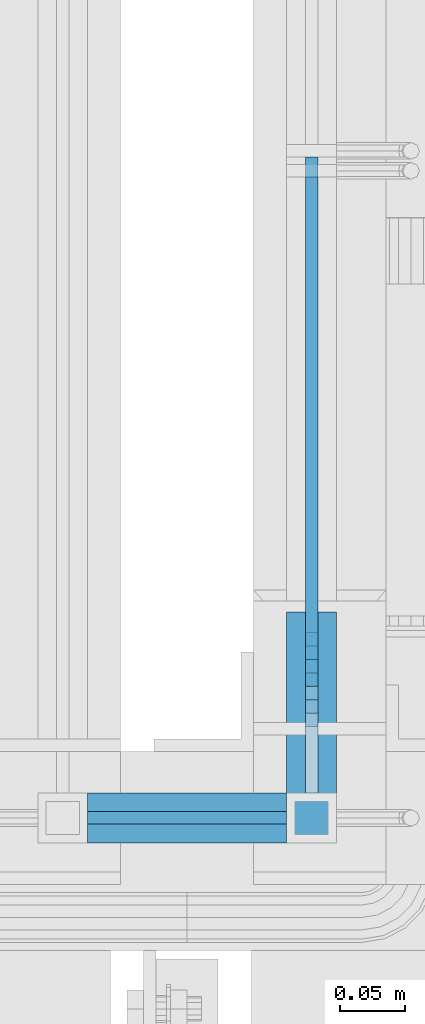
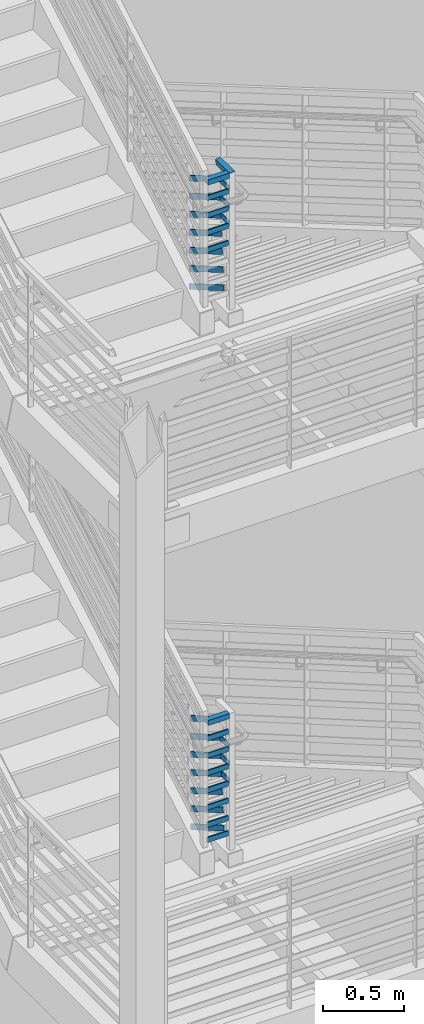
# One storey, part 859 of 1179: 19 beams, 15 members, 2 elements without a shape of their own.
"""IFC2X3 building model written with IfcOpenShell, lengths in millimetres."""

from ifc_helpers import new_model, si_unit, frame, origin_with_axes, place, context, subcontext, project, spatial, faceted_brep, material, type_object, element, aggregate, save


model = new_model("IFC2X3")

# Units and contexts
model_context = context("Model", 3, precision=1e-05, world=origin_with_axes())
body_context = subcontext(model_context, "Body", "Model", "MODEL_VIEW")
ifc_project = project(units=[si_unit("LENGTHUNIT", "METRE", prefix="MILLI"), si_unit("AREAUNIT", "SQUARE_METRE"), si_unit("VOLUMEUNIT", "CUBIC_METRE"), si_unit("MASSUNIT", "GRAM", prefix="KILO"), si_unit("TIMEUNIT", "SECOND"), si_unit("PLANEANGLEUNIT", "RADIAN"), si_unit("SOLIDANGLEUNIT", "STERADIAN"), si_unit("THERMODYNAMICTEMPERATUREUNIT", "DEGREE_CELSIUS"), si_unit("LUMINOUSINTENSITYUNIT", "LUMEN")], contexts=[model_context])

# Site, building, storey
site_placement = place(None, origin_with_axes())
site = spatial("IfcSite", under=ifc_project, at=site_placement, CompositionType="ELEMENT")
building_placement = place(site_placement, origin_with_axes())
building = spatial("IfcBuilding", under=site, at=building_placement, Name="Undefined", CompositionType="ELEMENT")
storey_placement = place(building_placement, origin_with_axes())
storey = spatial("IfcBuildingStorey", under=building, at=storey_placement, Name="Undefined", CompositionType="ELEMENT", Elevation=0.0)

# Assembly, beams
assembly_1_placement = place(storey_placement, origin_with_axes())
assembly_1 = element("IfcElementAssembly", 1, at=assembly_1_placement, inside=storey, Name="GUARDRAIL", AssemblyPlace="NOTDEFINED", PredefinedType="RIGID_FRAME")
ifc_material_1 = material(Name="STEEL/A36")
beam_type_1 = type_object("IfcBeamType", PredefinedType="NOTDEFINED")
beam_1_placement = place(assembly_1_placement, frame((-1828.80000153055, 31737.299999989, 6740.52488299739), z_axis=(0.0, 0.0, 1.0), x_axis=(0.999999999938439, 1.10960000217655e-05, 0.0)))
beam_1 = element("IfcBeam", 2, at=beam_1_placement, type_object=beam_type_1, material=ifc_material_1, Name="PLATE", context=body_context, shape_type="Brep", body=[
    faceted_brep([(0.0, 4.76250000000073, -19.05), (0.0, 4.76250000000073, 19.0499992370605), (152.399956117868, 4.76250000043365, 19.0500000000002), (152.399956117868, 4.76250000043365, -19.0500000000002), (0.0, -4.76250000000073, 19.0499992370605), (152.399956117868, -4.76249999959691, 19.0500000000002), (0.0, -4.76250000000073, -19.05), (152.399956117868, -4.76249999959691, -19.0500000000002)], [[[0, 1, 2, 3]], [[1, 4, 5, 2]], [[4, 6, 7, 5]], [[6, 0, 3, 7]], [[5, 7, 3, 2]], [[6, 4, 1, 0]]]),
])
beam_2_placement = place(assembly_1_placement, frame((-1828.80000153055, 31737.299999989, 6870.69988299459), z_axis=(0.0, 0.0, 1.0), x_axis=(0.999999999938439, 1.10960000217655e-05, 0.0)))
beam_2 = element("IfcBeam", 3, at=beam_2_placement, type_object=beam_type_1, material=ifc_material_1, Name="PLATE", context=body_context, shape_type="Brep", body=[
    faceted_brep([(0.0, 4.76250000000073, -19.05), (0.0, 4.76250000000073, 19.0499992370605), (152.399956117868, 4.76250000043365, 19.0500000000002), (152.399956117868, 4.76250000043365, -19.0500000000002), (0.0, -4.76250000000073, 19.0499992370605), (152.399956117868, -4.76249999959691, 19.0500000000002), (0.0, -4.76250000000073, -19.05), (152.399956117868, -4.76249999959691, -19.0500000000002)], [[[0, 1, 2, 3]], [[1, 4, 5, 2]], [[4, 6, 7, 5]], [[6, 0, 3, 7]], [[5, 7, 3, 2]], [[6, 4, 1, 0]]]),
])
beam_3_placement = place(assembly_1_placement, frame((-1828.80000153055, 31737.299999989, 7000.87488299804), z_axis=(0.0, 0.0, 1.0), x_axis=(0.999999999938439, 1.10960000217655e-05, 0.0)))
beam_3 = element("IfcBeam", 4, at=beam_3_placement, type_object=beam_type_1, material=ifc_material_1, Name="PLATE", context=body_context, shape_type="Brep", body=[
    faceted_brep([(0.0, 4.76250000000073, -19.05), (0.0, 4.76250000000073, 19.0499992370605), (152.399956117868, 4.76250000043365, 19.0500000000002), (152.399956117868, 4.76250000043365, -19.0500000000002), (0.0, -4.76250000000073, 19.0499992370605), (152.399956117868, -4.76249999959691, 19.0500000000002), (0.0, -4.76250000000073, -19.05), (152.399956117868, -4.76249999959691, -19.0500000000002)], [[[0, 1, 2, 3]], [[1, 4, 5, 2]], [[4, 6, 7, 5]], [[6, 0, 3, 7]], [[5, 7, 3, 2]], [[6, 4, 1, 0]]]),
])
beam_4_placement = place(assembly_1_placement, frame((-1828.80000153055, 31737.299999989, 7131.04988300441), z_axis=(0.0, 0.0, 1.0), x_axis=(0.999999999938439, 1.10960000217655e-05, 0.0)))
beam_4 = element("IfcBeam", 5, at=beam_4_placement, type_object=beam_type_1, material=ifc_material_1, Name="PLATE", context=body_context, shape_type="Brep", body=[
    faceted_brep([(0.0, 4.76250000000073, -19.05), (0.0, 4.76250000000073, 19.0499992370605), (152.399956117868, 4.76250000043365, 19.0500000000002), (152.399956117868, 4.76250000043365, -19.0500000000002), (0.0, -4.76250000000073, 19.0499992370605), (152.399956117868, -4.76249999959691, 19.0500000000002), (0.0, -4.76250000000073, -19.05), (152.399956117868, -4.76249999959691, -19.0500000000002)], [[[0, 1, 2, 3]], [[1, 4, 5, 2]], [[4, 6, 7, 5]], [[6, 0, 3, 7]], [[5, 7, 3, 2]], [[6, 4, 1, 0]]]),
])

assembly_2_placement = place(storey_placement, origin_with_axes())
assembly_2 = element("IfcElementAssembly", 6, at=assembly_2_placement, inside=storey, Name="GUARDRAIL", AssemblyPlace="NOTDEFINED", PredefinedType="RIGID_FRAME")
beam_5_placement = place(assembly_2_placement, frame((-1828.80000153055, 31737.299999338, 2292.40288892326), z_axis=(0.0, 0.0, 1.0), x_axis=(0.999999999938439, 1.10960000217655e-05, 0.0)))
beam_5 = element("IfcBeam", 7, at=beam_5_placement, type_object=beam_type_1, material=ifc_material_1, Name="PLATE", context=body_context, shape_type="Brep", body=[
    faceted_brep([(0.0, 4.76250000000073, -19.05), (0.0, 4.76250000000073, 19.0499992370605), (152.399956117868, 4.76250000043365, 19.0500000000002), (152.399956117868, 4.76250000043365, -19.0500000000002), (0.0, -4.76250000000073, 19.0499992370605), (152.399956117868, -4.76249999959691, 19.0500000000002), (0.0, -4.76250000000073, -19.05), (152.399956117868, -4.76249999959691, -19.0500000000002)], [[[0, 1, 2, 3]], [[1, 4, 5, 2]], [[4, 6, 7, 5]], [[6, 0, 3, 7]], [[5, 7, 3, 2]], [[6, 4, 1, 0]]]),
])
beam_6_placement = place(assembly_2_placement, frame((-1828.80000153055, 31737.299999338, 2406.70288909744), z_axis=(0.0, 0.0, 1.0), x_axis=(0.999999999938439, 1.10960000217655e-05, 0.0)))
beam_6 = element("IfcBeam", 8, at=beam_6_placement, type_object=beam_type_1, material=ifc_material_1, Name="PLATE", context=body_context, shape_type="Brep", body=[
    faceted_brep([(0.0, 4.76250000000073, -19.05), (0.0, 4.76250000000073, 19.0499992370605), (152.399956117868, 4.76250000043365, 19.0500000000002), (152.399956117868, 4.76250000043365, -19.0500000000002), (0.0, -4.76250000000073, 19.0499992370605), (152.399956117868, -4.76249999959691, 19.0500000000002), (0.0, -4.76250000000073, -19.05), (152.399956117868, -4.76249999959691, -19.0500000000002)], [[[0, 1, 2, 3]], [[1, 4, 5, 2]], [[4, 6, 7, 5]], [[6, 0, 3, 7]], [[5, 7, 3, 2]], [[6, 4, 1, 0]]]),
])
beam_7_placement = place(assembly_2_placement, frame((-1828.80000153055, 31737.299999989, 2536.8778889305), z_axis=(0.0, 0.0, 1.0), x_axis=(0.999999999938439, 1.10960000217655e-05, 0.0)))
beam_7 = element("IfcBeam", 9, at=beam_7_placement, type_object=beam_type_1, material=ifc_material_1, Name="PLATE", context=body_context, shape_type="Brep", body=[
    faceted_brep([(0.0, 4.76250000000073, -19.05), (0.0, 4.76250000000073, 19.0499992370605), (152.399956117868, 4.76250000043365, 19.0500000000002), (152.399956117868, 4.76250000043365, -19.0500000000002), (0.0, -4.76250000000073, 19.0499992370605), (152.399956117868, -4.76249999959691, 19.0500000000002), (0.0, -4.76250000000073, -19.05), (152.399956117868, -4.76249999959691, -19.0500000000002)], [[[0, 1, 2, 3]], [[1, 4, 5, 2]], [[4, 6, 7, 5]], [[6, 0, 3, 7]], [[5, 7, 3, 2]], [[6, 4, 1, 0]]]),
])
beam_8_placement = place(assembly_2_placement, frame((-1828.80000153055, 31737.299999989, 2667.05288994364), z_axis=(0.0, 0.0, 1.0), x_axis=(0.999999999938439, 1.10960000217655e-05, 0.0)))
beam_8 = element("IfcBeam", 10, at=beam_8_placement, type_object=beam_type_1, material=ifc_material_1, Name="PLATE", context=body_context, shape_type="Brep", body=[
    faceted_brep([(0.0, 4.76250000000073, -19.05), (0.0, 4.76250000000073, 19.0499992370605), (152.399956117868, 4.76250000043365, 19.0500000000002), (152.399956117868, 4.76250000043365, -19.0500000000002), (0.0, -4.76250000000073, 19.0499992370605), (152.399956117868, -4.76249999959691, 19.0500000000002), (0.0, -4.76250000000073, -19.05), (152.399956117868, -4.76249999959691, -19.0500000000002)], [[[0, 1, 2, 3]], [[1, 4, 5, 2]], [[4, 6, 7, 5]], [[6, 0, 3, 7]], [[5, 7, 3, 2]], [[6, 4, 1, 0]]]),
])
beam_9_placement = place(assembly_2_placement, frame((-1828.80000153055, 31737.299999989, 2797.22788994084), z_axis=(0.0, 0.0, 1.0), x_axis=(0.999999999938439, 1.10960000217655e-05, 0.0)))
beam_9 = element("IfcBeam", 11, at=beam_9_placement, type_object=beam_type_1, material=ifc_material_1, Name="PLATE", context=body_context, shape_type="Brep", body=[
    faceted_brep([(0.0, 4.76250000000073, -19.05), (0.0, 4.76250000000073, 19.0499992370605), (152.399956117868, 4.76250000043365, 19.0500000000002), (152.399956117868, 4.76250000043365, -19.0500000000002), (0.0, -4.76250000000073, 19.0499992370605), (152.399956117868, -4.76249999959691, 19.0500000000002), (0.0, -4.76250000000073, -19.05), (152.399956117868, -4.76249999959691, -19.0500000000002)], [[[0, 1, 2, 3]], [[1, 4, 5, 2]], [[4, 6, 7, 5]], [[6, 0, 3, 7]], [[5, 7, 3, 2]], [[6, 4, 1, 0]]]),
])
beam_10_placement = place(assembly_2_placement, frame((-1828.80000153055, 31737.299999989, 2927.40288994429), z_axis=(0.0, 0.0, 1.0), x_axis=(0.999999999938439, 1.10960000217655e-05, 0.0)))
beam_10 = element("IfcBeam", 12, at=beam_10_placement, type_object=beam_type_1, material=ifc_material_1, Name="PLATE", context=body_context, shape_type="Brep", body=[
    faceted_brep([(0.0, 4.76250000000073, -19.05), (0.0, 4.76250000000073, 19.0499992370605), (152.399956117868, 4.76250000043365, 19.0500000000002), (152.399956117868, 4.76250000043365, -19.0500000000002), (0.0, -4.76250000000073, 19.0499992370605), (152.399956117868, -4.76249999959691, 19.0500000000002), (0.0, -4.76250000000073, -19.05), (152.399956117868, -4.76249999959691, -19.0500000000002)], [[[0, 1, 2, 3]], [[1, 4, 5, 2]], [[4, 6, 7, 5]], [[6, 0, 3, 7]], [[5, 7, 3, 2]], [[6, 4, 1, 0]]]),
])
beam_11_placement = place(assembly_2_placement, frame((-1828.80000153055, 31737.299999989, 3057.57788995065), z_axis=(0.0, 0.0, 1.0), x_axis=(0.999999999938439, 1.10960000217655e-05, 0.0)))
beam_11 = element("IfcBeam", 13, at=beam_11_placement, type_object=beam_type_1, material=ifc_material_1, Name="PLATE", context=body_context, shape_type="Brep", body=[
    faceted_brep([(0.0, 4.76250000000073, -19.05), (0.0, 4.76250000000073, 19.0499992370605), (152.399956117868, 4.76250000043365, 19.0500000000002), (152.399956117868, 4.76250000043365, -19.0500000000002), (0.0, -4.76250000000073, 19.0499992370605), (152.399956117868, -4.76249999959691, 19.0500000000002), (0.0, -4.76250000000073, -19.05), (152.399956117868, -4.76249999959691, -19.0500000000002)], [[[0, 1, 2, 3]], [[1, 4, 5, 2]], [[4, 6, 7, 5]], [[6, 0, 3, 7]], [[5, 7, 3, 2]], [[6, 4, 1, 0]]]),
])

# Beam
beam_12_placement = place(assembly_1_placement, frame((-1657.3499991948, 31858.8284960123, 6870.69999961486), z_axis=(0.0, 0.0, 1.0), x_axis=(0.0, -1.0, 0.0)))
beam_12 = element("IfcBeam", 14, at=beam_12_placement, type_object=beam_type_1, material=ifc_material_1, Name="PLATE", context=body_context, shape_type="Brep", body=[
    faceted_brep([(10.6029629866134, 4.76250000000005, -19.0499999999975), (0.302660475197627, 4.76250000000005, 19.0500000000011), (102.476805941507, 4.76250000000005, 19.0499999999538), (102.476805979608, 4.76250000000005, -19.0500000000457), (0.302660475197627, -4.76250000000005, 19.0500000000011), (102.476805941507, -4.76250000000005, 19.0499999999538), (10.6029629866134, -4.76250000000005, -19.0499999999975), (102.476805979608, -4.76250000000005, -19.0500000000457)], [[[0, 1, 2, 3]], [[1, 4, 5, 2]], [[4, 6, 7, 5]], [[6, 0, 3, 7]], [[5, 7, 3, 2]], [[6, 4, 1, 0]]]),
])

beam_13_placement = place(assembly_1_placement, frame((-1657.3499991948, 31869.1287984822, 7000.87499958254), z_axis=(0.0, 0.0, 1.0), x_axis=(0.0, -1.0, 0.0)))
beam_13 = element("IfcBeam", 15, at=beam_13_placement, type_object=beam_type_1, material=ifc_material_1, Name="PLATE", context=body_context, shape_type="Brep", body=[
    faceted_brep([(10.6029629866134, 4.76250000000005, -19.0499999999975), (0.302660475197627, 4.76250000000005, 19.0500000000011), (112.77710843048, 4.76250000000005, 19.0500000000002), (112.77710843048, 4.76250000000005, -19.0500000000002), (0.302660475197627, -4.76250000000005, 19.0500000000011), (112.77710843048, -4.76250000000005, 19.0500000000002), (10.6029629866134, -4.76250000000005, -19.0499999999975), (112.77710843048, -4.76250000000005, -19.0500000000002)], [[[0, 1, 2, 3]], [[1, 4, 5, 2]], [[4, 6, 7, 5]], [[6, 0, 3, 7]], [[5, 7, 3, 2]], [[6, 4, 1, 0]]]),
])

beam_14_placement = place(assembly_1_placement, frame((-1657.3499991948, 31879.4291009466, 7131.0499995581), z_axis=(0.0, 0.0, 1.0), x_axis=(0.0, -1.0, 0.0)))
beam_14 = element("IfcBeam", 16, at=beam_14_placement, type_object=beam_type_1, material=ifc_material_1, Name="PLATE", context=body_context, shape_type="Brep", body=[
    faceted_brep([(10.6029629866134, 4.76250000000005, -19.0499999999975), (0.302660475197627, 4.76250000000005, 19.0500000000011), (123.077410894952, 4.76250000000005, 19.0500000000002), (123.077410894952, 4.76250000000005, -19.0500000000002), (0.302660475197627, -4.76250000000005, 19.0500000000011), (123.077410894952, -4.76250000000005, 19.0500000000002), (10.6029629866134, -4.76250000000005, -19.0499999999975), (123.077410894952, -4.76250000000005, -19.0500000000002)], [[[0, 1, 2, 3]], [[1, 4, 5, 2]], [[4, 6, 7, 5]], [[6, 0, 3, 7]], [[5, 7, 3, 2]], [[6, 4, 1, 0]]]),
])

beam_15_placement = place(assembly_2_placement, frame((-1657.3499991948, 31848.7630229584, 2667.05291886964), z_axis=(0.0, 0.0, 1.0), x_axis=(0.0, -1.0, 0.0)))
beam_15 = element("IfcBeam", 17, at=beam_15_placement, type_object=beam_type_1, material=ifc_material_1, Name="PLATE", context=body_context, shape_type="Brep", body=[
    faceted_brep([(10.6006355317113, 4.76250000000005, -19.0500000000002), (0.366391600862698, 4.76250000000005, 19.0500000000002), (92.4121460114256, 4.76250000000005, 19.0500000000002), (92.4122106290233, 4.76250000000005, -19.0500000000002), (0.366391600862698, -4.76250000000005, 19.0500000000002), (92.4121460114256, -4.76250000000005, 19.0500000000002), (10.6006355317113, -4.76250000000005, -19.0500000000002), (92.4122106290233, -4.76250000000005, -19.0500000000002)], [[[0, 1, 2, 3]], [[1, 4, 5, 2]], [[4, 6, 7, 5]], [[6, 0, 3, 7]], [[5, 7, 3, 2]], [[6, 4, 1, 0]]]),
])

beam_16_placement = place(assembly_2_placement, frame((-1657.3499991948, 31858.9972669712, 2797.22791886683), z_axis=(0.0, 0.0, 1.0), x_axis=(0.0, -1.0, 0.0)))
beam_16 = element("IfcBeam", 18, at=beam_16_placement, type_object=beam_type_1, material=ifc_material_1, Name="PLATE", context=body_context, shape_type="Brep", body=[
    faceted_brep([(10.6006355317113, 4.76250000000005, -19.0500000000002), (0.366391600862698, 4.76250000000005, 19.0500000000002), (102.646169247444, 4.76250000000005, 19.0500000000002), (102.646233865042, 4.76250000000005, -19.0500000000002), (0.366391600862698, -4.76250000000005, 19.0500000000002), (102.646169247444, -4.76250000000005, 19.0500000000002), (10.6006355317113, -4.76250000000005, -19.0500000000002), (102.646233865042, -4.76250000000005, -19.0500000000002)], [[[0, 1, 2, 3]], [[1, 4, 5, 2]], [[4, 6, 7, 5]], [[6, 0, 3, 7]], [[5, 7, 3, 2]], [[6, 4, 1, 0]]]),
])

beam_17_placement = place(assembly_2_placement, frame((-1657.3499991948, 31869.2315109734, 2927.40291887029), z_axis=(0.0, 0.0, 1.0), x_axis=(0.0, -1.0, 0.0)))
beam_17 = element("IfcBeam", 19, at=beam_17_placement, type_object=beam_type_1, material=ifc_material_1, Name="PLATE", context=body_context, shape_type="Brep", body=[
    faceted_brep([(10.6006355317113, 4.76250000000005, -19.0500000000002), (0.366391600862698, 4.76250000000005, 19.0500000000002), (112.880192472781, 4.76250000000005, 19.0500000000002), (112.880257090379, 4.76250000000005, -19.0500000000002), (0.366391600862698, -4.76250000000005, 19.0500000000002), (112.880192472781, -4.76250000000005, 19.0500000000002), (10.6006355317113, -4.76250000000005, -19.0500000000002), (112.880257090379, -4.76250000000005, -19.0500000000002)], [[[0, 1, 2, 3]], [[1, 4, 5, 2]], [[4, 6, 7, 5]], [[6, 0, 3, 7]], [[5, 7, 3, 2]], [[6, 4, 1, 0]]]),
])

ifc_material_2 = material()
beam_type_2 = type_object("IfcBeamType", Name="HSS1-1/2X1-1/2X1/4", PredefinedType="NOTDEFINED")
beam_18_placement = place(assembly_1_placement, frame((-1828.80000153055, 31737.299999989, 7258.04991007081), z_axis=(0.0, 0.0, 1.0), x_axis=(0.999999999938439, 1.10960000217655e-05, 0.0)))
beam_18 = element("IfcBeam", 20, at=beam_18_placement, type_object=beam_type_2, material=ifc_material_2, Name="POST", ObjectType="HSS1-1/2X1-1/2X1/4", context=body_context, shape_type="Brep", body=[
    faceted_brep([(2.27373675443232e-13, 12.6999993300487, -12.6999993299996), (-6.82121026329696e-13, -12.6999993300415, -12.6999993299996), (152.399815200261, -12.6999993296267, -12.6999993299996), (152.399815200262, 12.6999993304562, -12.6999993299996), (-6.82121026329696e-13, -12.6999993300415, 12.6999993299996), (152.399815200261, -12.6999993296267, 12.6999993299996), (2.27373675443232e-13, 12.6999993300487, 12.6999993299996), (152.399815200262, 12.6999993304562, 12.6999993299996), (0.0, 19.0499992350015, -19.0499992349996), (0.0, 19.0499992350015, 19.0499992349996), (152.399815200263, 19.0499992354817, 19.0499992349996), (152.399815200263, 19.0499992354817, -19.0499992349996), (0.0, -19.0499992350015, 19.0499992349996), (152.399815200261, -19.0499992346522, 19.0499992349996), (0.0, -19.0499992350015, -19.0499992349996), (152.399815200261, -19.0499992346522, -19.0499992349996)], [[[0, 1, 2, 3]], [[1, 4, 5, 2]], [[4, 6, 7, 5]], [[6, 0, 3, 7]], [[8, 9, 10, 11]], [[9, 12, 13, 10]], [[12, 14, 15, 13]], [[14, 8, 11, 15]], [[13, 15, 11, 10], [5, 7, 3, 2]], [[14, 12, 9, 8], [6, 4, 1, 0]]]),
])

beam_19_placement = place(assembly_2_placement, frame((-1828.80000153055, 31737.299999989, 3184.57791701706), z_axis=(0.0, 0.0, 1.0), x_axis=(0.999999999938439, 1.10960000217655e-05, 0.0)))
beam_19 = element("IfcBeam", 21, at=beam_19_placement, type_object=beam_type_2, material=ifc_material_2, Name="POST", ObjectType="HSS1-1/2X1-1/2X1/4", context=body_context, shape_type="Brep", body=[
    faceted_brep([(2.27373675443232e-13, 12.6999993300487, -12.6999993299996), (-6.82121026329696e-13, -12.6999993300415, -12.6999993299996), (152.399815200261, -12.6999993296267, -12.6999993299996), (152.399815200262, 12.6999993304562, -12.6999993299996), (-6.82121026329696e-13, -12.6999993300415, 12.6999993299996), (152.399815200261, -12.6999993296267, 12.6999993299996), (2.27373675443232e-13, 12.6999993300487, 12.6999993299996), (152.399815200262, 12.6999993304562, 12.6999993299996), (0.0, 19.0499992350015, -19.0499992349996), (0.0, 19.0499992350015, 19.0499992349996), (152.399815200263, 19.0499992354817, 19.0499992349996), (152.399815200263, 19.0499992354817, -19.0499992349996), (0.0, -19.0499992350015, 19.0499992349996), (152.399815200261, -19.0499992346522, 19.0499992349996), (0.0, -19.0499992350015, -19.0499992349996), (152.399815200261, -19.0499992346522, -19.0499992349996)], [[[0, 1, 2, 3]], [[1, 4, 5, 2]], [[4, 6, 7, 5]], [[6, 0, 3, 7]], [[8, 9, 10, 11]], [[9, 12, 13, 10]], [[12, 14, 15, 13]], [[14, 8, 11, 15]], [[13, 15, 11, 10], [5, 7, 3, 2]], [[14, 12, 9, 8], [6, 4, 1, 0]]]),
])

# Member
member_type_1 = type_object("IfcMemberType", PredefinedType="NOTDEFINED")
member_1_placement = place(assembly_1_placement, frame((-1657.3499991948, 32238.2402883952, 6101.46163475831), z_axis=(0.0, 0.503871025834968, 0.863778900717086), x_axis=(0.0, -0.863778900717086, 0.503871025834967)))
member_1 = element("IfcMember", 22, at=member_1_placement, type_object=member_type_1, material=ifc_material_1, Name="PLATE", context=body_context, shape_type="Brep", body=[
    faceted_brep([(-16.7114354625264, 4.76250000000005, -19.0500000000065), (5.51356370517169, 4.76250000000005, 19.0500000000338), (498.408052196759, 4.76250000000005, 19.0499999995518), (488.107749713748, 4.76250000000005, -19.0500000004249), (5.51356370517169, -4.76250000000005, 19.0500000000338), (498.408052196759, -4.76250000000005, 19.0499999995518), (-16.7114354625264, -4.76250000000005, -19.0500000000065), (488.107749713748, -4.76250000000005, -19.0500000004249)], [[[0, 1, 2, 3]], [[1, 4, 5, 2]], [[4, 6, 7, 5]], [[6, 0, 3, 7]], [[5, 7, 3, 2]], [[6, 4, 1, 0]]]),
])

member_2_placement = place(assembly_1_placement, frame((-1657.3499991948, 32238.2401810984, 6237.64514441344), z_axis=(0.0, 0.503871025834968, 0.863778900717086), x_axis=(0.0, -0.863778900717086, 0.503871025834967)))
member_2 = element("IfcMember", 23, at=member_2_placement, type_object=member_type_1, material=ifc_material_1, Name="PLATE", context=body_context, shape_type="Brep", body=[
    faceted_brep([(-16.7114354625264, 4.76250000000005, -19.0500000000065), (5.51356370517169, 4.76250000000005, 19.0500000000338), (486.483356957822, 4.76250000000005, 19.0499999997046), (476.18305452654, 4.76250000000005, -19.0500000002503), (5.51356370517169, -4.76250000000005, 19.0500000000338), (486.483356957822, -4.76250000000005, 19.0499999997046), (-16.7114354625264, -4.76250000000005, -19.0500000000065), (476.18305452654, -4.76250000000005, -19.0500000002503)], [[[0, 1, 2, 3]], [[1, 4, 5, 2]], [[4, 6, 7, 5]], [[6, 0, 3, 7]], [[5, 7, 3, 2]], [[6, 4, 1, 0]]]),
])

member_3_placement = place(assembly_1_placement, frame((-1657.3499991948, 32238.2403455292, 6373.82865410964), z_axis=(0.0, 0.503871025834968, 0.863778900717086), x_axis=(0.0, -0.863778900717086, 0.503871025834967)))
member_3 = element("IfcMember", 24, at=member_3_placement, type_object=member_type_1, material=ifc_material_1, Name="PLATE", context=body_context, shape_type="Brep", body=[
    faceted_brep([(-16.7114354625264, 4.76250000000005, -19.0500000000065), (5.51356370517169, 4.76250000000005, 19.0500000000338), (474.558657059013, 4.76250000000005, 19.04999999957), (464.258354576003, 4.76250000000005, -19.0500000004031), (5.51356370517169, -4.76250000000005, 19.0500000000338), (474.558657059013, -4.76250000000005, 19.04999999957), (-16.7114354625264, -4.76250000000005, -19.0500000000065), (464.258354576003, -4.76250000000005, -19.0500000004031)], [[[0, 1, 2, 3]], [[1, 4, 5, 2]], [[4, 6, 7, 5]], [[6, 0, 3, 7]], [[5, 7, 3, 2]], [[6, 4, 1, 0]]]),
])

member_4_placement = place(assembly_1_placement, frame((-1657.3499991948, 32238.2399215749, 6510.01216378485), z_axis=(0.0, 0.503871025834968, 0.863778900717086), x_axis=(0.0, -0.863778900717086, 0.503871025834967)))
member_4 = element("IfcMember", 25, at=member_4_placement, type_object=member_type_1, material=ifc_material_1, Name="PLATE", context=body_context, shape_type="Brep", body=[
    faceted_brep([(-16.7114354625264, 4.76250000000005, -19.0500000000065), (5.51356370517169, 4.76250000000005, 19.0500000000338), (462.633959553707, 4.76249999999982, 19.0499999995809), (452.33365723924, 4.76249999999982, -19.0500000003922), (5.51356370517169, -4.76250000000005, 19.0500000000338), (462.633959553707, -4.76250000000027, 19.0499999995809), (-16.7114354625264, -4.76250000000005, -19.0500000000065), (452.33365723924, -4.76250000000027, -19.0500000003922)], [[[0, 1, 2, 3]], [[1, 4, 5, 2]], [[4, 6, 7, 5]], [[6, 0, 3, 7]], [[5, 7, 3, 2]], [[6, 4, 1, 0]]]),
])

member_5_placement = place(assembly_1_placement, frame((-1657.3499991948, 32238.2402430829, 6646.19567346003), z_axis=(0.0, 0.503871025834968, 0.863778900717086), x_axis=(0.0, -0.863778900717086, 0.503871025834967)))
member_5 = element("IfcMember", 26, at=member_5_placement, type_object=member_type_1, material=ifc_material_1, Name="PLATE", context=body_context, shape_type="Brep", body=[
    faceted_brep([(-16.7114354625264, 4.76250000000005, -19.0500000000065), (5.51356370517169, 4.76250000000005, 19.0500000000338), (450.709261800912, 4.76250000000005, 19.0499999995882), (440.408959486438, 4.76250000000005, -19.0500000003849), (5.51356370517169, -4.76250000000005, 19.0500000000338), (450.709261800912, -4.76250000000005, 19.0499999995882), (-16.7114354625264, -4.76250000000005, -19.0500000000065), (440.408959486438, -4.76250000000005, -19.0500000003849)], [[[0, 1, 2, 3]], [[1, 4, 5, 2]], [[4, 6, 7, 5]], [[6, 0, 3, 7]], [[5, 7, 3, 2]], [[6, 4, 1, 0]]]),
])

member_6_placement = place(assembly_1_placement, frame((-1657.3499991948, 32238.2402432276, 6782.37918313535), z_axis=(0.0, 0.503871025834968, 0.863778900717086), x_axis=(0.0, -0.863778900717086, 0.503871025834967)))
member_6 = element("IfcMember", 27, at=member_6_placement, type_object=member_type_1, material=ifc_material_1, Name="PLATE", context=body_context, shape_type="Brep", body=[
    faceted_brep([(-16.7114354625264, 4.76250000000005, -19.0500000000065), (5.51356370517169, 4.76250000000005, 19.0500000000338), (438.784564012589, 4.76250000000005, 19.0499999995955), (428.484261708796, 4.76250000000005, -19.0500000003776), (5.51356370517169, -4.76250000000005, 19.0500000000338), (438.784564012589, -4.76250000000005, 19.0499999995955), (-16.7114354625264, -4.76250000000005, -19.0500000000065), (428.484261708796, -4.76250000000005, -19.0500000003776)], [[[0, 1, 2, 3]], [[1, 4, 5, 2]], [[4, 6, 7, 5]], [[6, 0, 3, 7]], [[5, 7, 3, 2]], [[6, 4, 1, 0]]]),
])

member_7_placement = place(assembly_1_placement, frame((-1657.3499991948, 32238.2402433512, 6918.56269281116), z_axis=(0.0, 0.503871025834968, 0.863778900717086), x_axis=(0.0, -0.863778900717086, 0.503871025834967)))
member_7 = element("IfcMember", 28, at=member_7_placement, type_object=member_type_1, material=ifc_material_1, Name="PLATE", context=body_context, shape_type="Brep", body=[
    faceted_brep([(-16.7114354625264, 4.76250000000005, -19.0500000000065), (5.51356370517169, 4.76250000000005, 19.0500000000338), (426.859866238374, 4.76250000000005, 19.04999999961), (416.559563934577, 4.76250000000005, -19.0500000003631), (5.51356370517169, -4.76250000000005, 19.0500000000338), (426.859866238374, -4.76250000000005, 19.04999999961), (-16.7114354625264, -4.76250000000005, -19.0500000000065), (416.559563934577, -4.76250000000005, -19.0500000003631)], [[[0, 1, 2, 3]], [[1, 4, 5, 2]], [[4, 6, 7, 5]], [[6, 0, 3, 7]], [[5, 7, 3, 2]], [[6, 4, 1, 0]]]),
])

member_8_placement = place(assembly_2_placement, frame((-1657.3499991948, 32223.0545030912, 2038.85780738598), z_axis=(0.0, 0.501075923252298, 0.865403327435744), x_axis=(0.0, -0.865403327435743, 0.501075923252299)))
member_8 = element("IfcMember", 29, at=member_8_placement, type_object=member_type_1, material=ifc_material_1, Name="PLATE", context=body_context, shape_type="Brep", body=[
    faceted_brep([(-16.5570104603576, 4.76250000000005, -19.0500000000102), (5.50317738577724, 4.76250000000005, 19.0499999999902), (479.436680006358, 4.76250000000005, 19.0499999999374), (469.202436082502, 4.76250000000005, -19.0500000000902), (5.50317738577724, -4.76250000000005, 19.0499999999902), (479.436680006358, -4.76250000000005, 19.0499999999374), (-16.5570104603576, -4.76250000000005, -19.0500000000102), (469.202436082502, -4.76250000000005, -19.0500000000902)], [[[0, 1, 2, 3]], [[1, 4, 5, 2]], [[4, 6, 7, 5]], [[6, 0, 3, 7]], [[5, 7, 3, 2]], [[6, 4, 1, 0]]]),
])

member_9_placement = place(assembly_2_placement, frame((-1657.3499991948, 32223.0545030912, 2174.9585220928), z_axis=(0.0, 0.501075923252298, 0.865403327435744), x_axis=(0.0, -0.865403327435743, 0.501075923252299)))
member_9 = element("IfcMember", 30, at=member_9_placement, type_object=member_type_1, material=ifc_material_1, Name="PLATE", context=body_context, shape_type="Brep", body=[
    faceted_brep([(-16.5570104603576, 4.76250000000005, -19.0500000000102), (5.50317738577724, 4.76250000000005, 19.0499999999902), (467.610698301269, 4.76250000000005, 19.0499999999374), (457.376454466914, 4.76250000000005, -19.0500000000829), (5.50317738577724, -4.76250000000005, 19.0499999999902), (467.610698301269, -4.76250000000005, 19.0499999999374), (-16.5570104603576, -4.76250000000005, -19.0500000000102), (457.376454466914, -4.76250000000005, -19.0500000000829)], [[[0, 1, 2, 3]], [[1, 4, 5, 2]], [[4, 6, 7, 5]], [[6, 0, 3, 7]], [[5, 7, 3, 2]], [[6, 4, 1, 0]]]),
])

member_10_placement = place(assembly_2_placement, frame((-1657.3499991948, 32223.0545030904, 2311.05923678509), z_axis=(0.0, 0.501075923252298, 0.865403327435744), x_axis=(0.0, -0.865403327435743, 0.501075923252299)))
member_10 = element("IfcMember", 31, at=member_10_placement, type_object=member_type_1, material=ifc_material_1, Name="PLATE", context=body_context, shape_type="Brep", body=[
    faceted_brep([(-16.5570104603576, 4.76250000000005, -19.0500000000102), (5.50317738577724, 4.76250000000005, 19.0499999999902), (455.784716617429, 4.76250000000005, 19.0499999999374), (445.550472693583, 4.76250000000005, -19.0500000000866), (5.50317738577724, -4.76250000000005, 19.0499999999902), (455.784716617429, -4.76250000000005, 19.0499999999374), (-16.5570104603576, -4.76250000000005, -19.0500000000102), (445.550472693583, -4.76250000000005, -19.0500000000866)], [[[0, 1, 2, 3]], [[1, 4, 5, 2]], [[4, 6, 7, 5]], [[6, 0, 3, 7]], [[5, 7, 3, 2]], [[6, 4, 1, 0]]]),
])

member_11_placement = place(assembly_2_placement, frame((-1657.3499991948, 32223.0545030888, 2447.1599515072), z_axis=(0.0, 0.501075923252298, 0.865403327435744), x_axis=(0.0, -0.865403327435743, 0.501075923252299)))
member_11 = element("IfcMember", 32, at=member_11_placement, type_object=member_type_1, material=ifc_material_1, Name="PLATE", context=body_context, shape_type="Brep", body=[
    faceted_brep([(-16.5570104603576, 4.76250000000005, -19.0500000000102), (5.50317738577724, 4.76250000000005, 19.0499999999902), (443.958736892662, 4.76250000000005, 19.0499999999411), (433.724492968806, 4.76250000000005, -19.0500000000793), (5.50317738577724, -4.76250000000005, 19.0499999999902), (443.958736892662, -4.76250000000005, 19.0499999999411), (-16.5570104603576, -4.76250000000005, -19.0500000000102), (433.724492968806, -4.76250000000005, -19.0500000000793)], [[[0, 1, 2, 3]], [[1, 4, 5, 2]], [[4, 6, 7, 5]], [[6, 0, 3, 7]], [[5, 7, 3, 2]], [[6, 4, 1, 0]]]),
])

member_12_placement = place(assembly_2_placement, frame((-1657.3499991948, 32223.0545030911, 2583.26066621188), z_axis=(0.0, 0.501075923252298, 0.865403327435744), x_axis=(0.0, -0.865403327435743, 0.501075923252299)))
member_12 = element("IfcMember", 33, at=member_12_placement, type_object=member_type_1, material=ifc_material_1, Name="PLATE", context=body_context, shape_type="Brep", body=[
    faceted_brep([(-16.5570104603576, 4.76250000000005, -19.0500000000102), (5.50317738577724, 4.76250000000005, 19.0499999999902), (432.132755175113, 4.76250000000005, 19.0499999999411), (421.898511251264, 4.76250000000005, -19.0500000000793), (5.50317738577724, -4.76250000000005, 19.0499999999902), (432.132755175113, -4.76250000000005, 19.0499999999411), (-16.5570104603576, -4.76250000000005, -19.0500000000102), (421.898511251264, -4.76250000000005, -19.0500000000793)], [[[0, 1, 2, 3]], [[1, 4, 5, 2]], [[4, 6, 7, 5]], [[6, 0, 3, 7]], [[5, 7, 3, 2]], [[6, 4, 1, 0]]]),
])

member_13_placement = place(assembly_2_placement, frame((-1657.3499991948, 32223.0545031135, 2719.36138091859), z_axis=(0.0, 0.501075923252298, 0.865403327435744), x_axis=(0.0, -0.865403327435743, 0.501075923252299)))
member_13 = element("IfcMember", 34, at=member_13_placement, type_object=member_type_1, material=ifc_material_1, Name="PLATE", context=body_context, shape_type="Brep", body=[
    faceted_brep([(-16.5570104603576, 4.76250000000005, -19.0500000000102), (5.50317738577724, 4.76250000000005, 19.0499999999902), (420.30677346604, 4.76250000000005, 19.0499999999447), (410.072529542191, 4.76250000000005, -19.0500000000757), (5.50317738577724, -4.76250000000005, 19.0499999999902), (420.30677346604, -4.76250000000005, 19.0499999999447), (-16.5570104603576, -4.76250000000005, -19.0500000000102), (410.072529542191, -4.76250000000005, -19.0500000000757)], [[[0, 1, 2, 3]], [[1, 4, 5, 2]], [[4, 6, 7, 5]], [[6, 0, 3, 7]], [[5, 7, 3, 2]], [[6, 4, 1, 0]]]),
])

member_14_placement = place(assembly_2_placement, frame((-1657.3499991948, 32223.0545032377, 2855.46209561345), z_axis=(0.0, 0.501075923252298, 0.865403327435744), x_axis=(0.0, -0.865403327435743, 0.501075923252299)))
member_14 = element("IfcMember", 35, at=member_14_placement, type_object=member_type_1, material=ifc_material_1, Name="PLATE", context=body_context, shape_type="Brep", body=[
    faceted_brep([(-16.5570104603576, 4.76250000000005, -19.0500000000102), (5.50317738577724, 4.76250000000005, 19.0499999999902), (408.480791786402, 4.76250000000005, 19.0499999999483), (398.246547862556, 4.76250000000005, -19.050000000072), (5.50317738577724, -4.76250000000005, 19.0499999999902), (408.480791786402, -4.76250000000005, 19.0499999999483), (-16.5570104603576, -4.76250000000005, -19.0500000000102), (398.246547862556, -4.76250000000005, -19.050000000072)], [[[0, 1, 2, 3]], [[1, 4, 5, 2]], [[4, 6, 7, 5]], [[6, 0, 3, 7]], [[5, 7, 3, 2]], [[6, 4, 1, 0]]]),
])

aggregate(assembly_2, [beam_5, beam_6, beam_7, beam_8, beam_9, beam_10, beam_11, beam_19, member_8, member_9, member_10, member_11, member_12, member_13, member_14, beam_15, beam_16, beam_17])

member_type_2 = type_object("IfcMemberType", Name="HSS1-1/2X1-1/2X1/4", PredefinedType="NOTDEFINED")
member_15_placement = place(assembly_1_placement, frame((-1657.34999921452, 31884.5828774407, 7258.04999816642), z_axis=(0.0, 0.0, 1.0), x_axis=(0.0, -1.0, 0.0)))
member_15 = element("IfcMember", 36, at=member_15_placement, type_object=member_type_2, material=ifc_material_2, Name="GUARDRAIL", ObjectType="HSS1-1/2X1-1/2X1/4", context=body_context, shape_type="Brep", body=[
    faceted_brep([(-1.71217286994215, 12.6999993300001, -12.6999993300005), (-1.71217286994215, -12.6999993300001, -12.6999993300005), (134.58118720464, -12.6999993300001, -12.6999993299487), (134.58118720464, 12.6999993300001, -12.6999993299487), (-8.58822170142594, -12.6999993300001, 12.6999993299969), (159.981186040644, -12.6999993300001, 12.6999993300615), (-8.58822170142594, 12.6999993300001, 12.6999993299969), (159.981186040644, 12.6999993300001, 12.6999993300615), (0.00683940290036844, 19.0499992350001, -19.0499992350005), (-10.3072339742685, 19.0499992350001, 19.0499992349969), (166.331185989646, 19.0499992350001, 19.0499992350633), (128.231187255638, 19.0499992350001, -19.0499992349514), (-10.3072339742685, -19.0499992350001, 19.0499992349969), (166.331185989646, -19.0499992350001, 19.0499992350633), (0.00683940290036844, -19.0499992350001, -19.0499992350005), (128.231187255638, -19.0499992350001, -19.0499992349514)], [[[0, 1, 2, 3]], [[1, 4, 5, 2]], [[4, 6, 7, 5]], [[6, 0, 3, 7]], [[8, 9, 10, 11]], [[9, 12, 13, 10]], [[12, 14, 15, 13]], [[14, 8, 11, 15]], [[13, 15, 11, 10], [5, 7, 3, 2]], [[14, 12, 9, 8], [6, 4, 1, 0]]]),
])

aggregate(assembly_1, [beam_1, beam_2, beam_3, beam_4, beam_18, member_1, member_2, member_3, member_4, member_5, member_6, member_7, beam_12, beam_13, beam_14, member_15])

save(model, "model.ifc")
